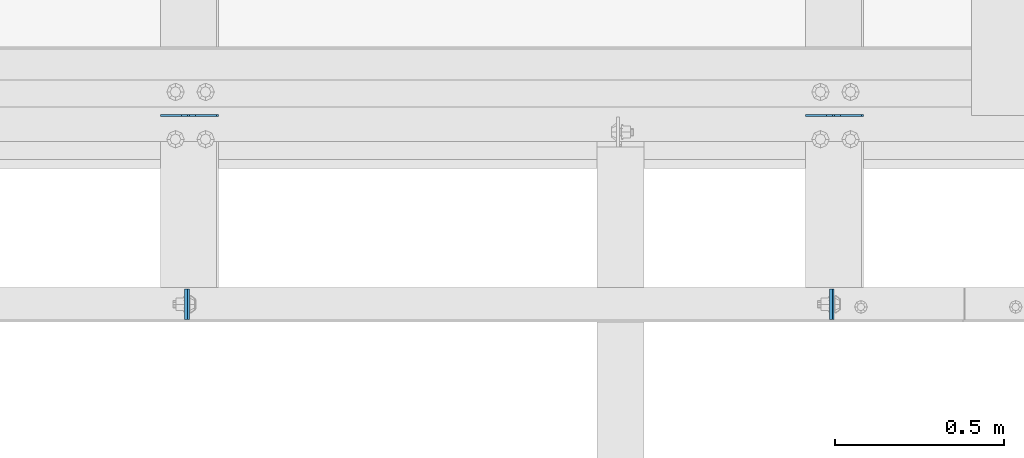
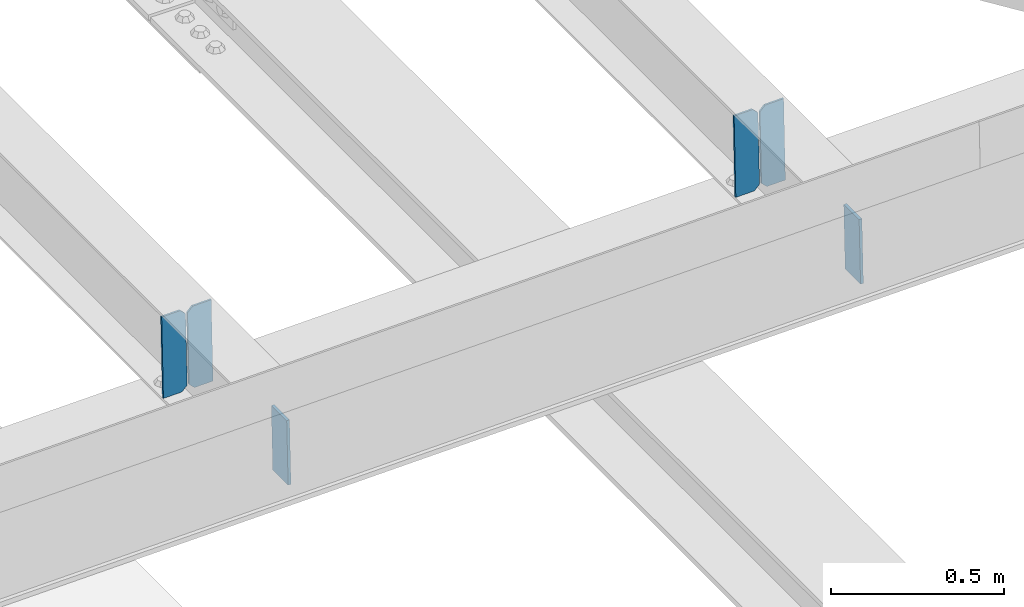
# One storey, part 3187 of 3843: 6 plates, 3 elements without a shape of their own.
"""IFC2X3 building model written with IfcOpenShell, lengths in millimetres."""

from ifc_helpers import new_model, si_unit, frame, origin_with_axes, place, context, subcontext, project, spatial, faceted_brep, material, type_object, element, aggregate, save


model = new_model("IFC2X3")

# Units and contexts
model_context = context("Model", 3, precision=1e-05, world=origin_with_axes())
body_context = subcontext(model_context, "Body", "Model", "MODEL_VIEW")
ifc_project = project(units=[si_unit("LENGTHUNIT", "METRE", prefix="MILLI"), si_unit("AREAUNIT", "SQUARE_METRE"), si_unit("VOLUMEUNIT", "CUBIC_METRE"), si_unit("MASSUNIT", "GRAM", prefix="KILO"), si_unit("TIMEUNIT", "SECOND"), si_unit("PLANEANGLEUNIT", "RADIAN"), si_unit("SOLIDANGLEUNIT", "STERADIAN"), si_unit("THERMODYNAMICTEMPERATUREUNIT", "DEGREE_CELSIUS"), si_unit("LUMINOUSINTENSITYUNIT", "LUMEN")], contexts=[model_context])

# Site, building, storey
site_placement = place(None, origin_with_axes())
site = spatial("IfcSite", under=ifc_project, at=site_placement, CompositionType="ELEMENT")
building_placement = place(site_placement, origin_with_axes())
building = spatial("IfcBuilding", under=site, at=building_placement, Name="Undefined", CompositionType="ELEMENT")
storey_placement = place(building_placement, origin_with_axes())
storey = spatial("IfcBuildingStorey", under=building, at=storey_placement, Name="Undefined", CompositionType="ELEMENT", Elevation=0.0)

# Assembly, plates
assembly_1_placement = place(storey_placement, origin_with_axes())
assembly_1 = element("IfcElementAssembly", 1, at=assembly_1_placement, inside=storey, Name="BEAM", AssemblyPlace="NOTDEFINED", PredefinedType="RIGID_FRAME")
ifc_material = material(Name="STEEL/A572-50")
plate_type_1 = type_object("IfcPlateType", PredefinedType="NOTDEFINED")
plate_1_placement = place(assembly_1_placement, frame((68337.6870661748, 25014.2376747884, 46363.5539819996), z_axis=(3.66789997933665e-05, 0.999999999327024, 7.76010238041635e-07), x_axis=(0.0211520550054438, 0.0, -0.999776270257025)))
plate_1 = element("IfcPlate", 2, at=plate_1_placement, type_object=plate_type_1, material=ifc_material, Name="PLATE", context=body_context, shape_type="Brep", body=[
    faceted_brep([(0.0, -4.76249999999709, 0.0), (0.0, -4.76249999999709, 88.9000015258789), (0.0, 4.76249999999709, 88.9000015258789), (0.0, 4.76249999999709, 0.0), (228.600006102781, -4.7625000004191, 88.9000015257589), (228.600006102781, 4.76249999954598, 88.9000015257443), (228.600006103079, -4.7625000004482, 7.27595761418343e-12), (228.600006103079, 4.76249999954598, -7.27595761418343e-12)], [[[0, 1, 2, 3]], [[1, 4, 5, 2]], [[4, 6, 7, 5]], [[6, 0, 3, 7]], [[5, 7, 3, 2]], [[6, 4, 1, 0]]]),
])
plate_2_placement = place(assembly_1_placement, frame((66432.6871638018, 25014.2376643107, 46323.2447316255), z_axis=(3.44799897284247e-05, 0.999999999405299, 7.29486360796727e-07), x_axis=(0.0211520550054438, 0.0, -0.999776270257025)))
plate_2 = element("IfcPlate", 3, at=plate_2_placement, type_object=plate_type_1, material=ifc_material, Name="PLATE", context=body_context, shape_type="Brep", body=[
    faceted_brep([(0.0, -4.76249999999709, 0.0), (0.0, -4.76249999999709, 88.9000015258789), (0.0, 4.76249999999709, 88.9000015258789), (0.0, 4.76249999999709, 0.0), (228.600006102781, -4.7625000004191, 88.9000015257589), (228.600006102781, 4.76249999954598, 88.9000015257443), (228.600006103079, -4.7625000004482, 7.27595761418343e-12), (228.600006103079, 4.76249999954598, -7.27595761418343e-12)], [[[0, 1, 2, 3]], [[1, 4, 5, 2]], [[4, 6, 7, 5]], [[6, 0, 3, 7]], [[5, 7, 3, 2]], [[6, 4, 1, 0]]]),
])
aggregate(assembly_1, [plate_1, plate_2])

assembly_2_placement = place(storey_placement, origin_with_axes())
assembly_2 = element("IfcElementAssembly", 4, at=assembly_2_placement, inside=storey, Name="BEAM", AssemblyPlace="NOTDEFINED", PredefinedType="RIGID_FRAME")
plate_type_2 = type_object("IfcPlateType", PredefinedType="NOTDEFINED")
plate_3_placement = place(assembly_2_placement, frame((68433.696478264, 25616.6676028813, 46104.5565711542), z_axis=(-0.0211520978230692, -0.00173405299920705, 0.99977476554366), x_axis=(-0.99977626935114, 3.66869999923657e-05, -0.0211520660073878)))
plate_3 = element("IfcPlate", 5, at=plate_3_placement, type_object=plate_type_2, material=ifc_material, Name="STIFFENER", context=body_context, shape_type="Brep", body=[
    faceted_brep([(0.0, -3.17499999999927, 0.0), (6.83940015733242e-10, -3.17499999996653, 288.924999998613), (6.54836185276508e-10, 3.17500000001746, 288.924999998591), (0.0, 3.17499999999927, 0.0), (61.9125003828667, -3.17499999997744, 288.924999998599), (61.9125003828522, 3.17500000002838, 288.924999998584), (79.3750000013097, -3.17499999997744, 271.462500380039), (79.375000001266, 3.17500000002838, 271.462500380017), (79.375000000713, -3.17499999999927, 17.4624996185448), (79.3750000006694, 3.17500000000291, 17.462499618523), (61.9125003821828, -3.17499999999563, -1.45519152283669e-11), (61.9125003821682, 3.17500000000655, -2.91038304567337e-11)], [[[0, 1, 2, 3]], [[1, 4, 5, 2]], [[4, 6, 7, 5]], [[6, 8, 9, 7]], [[8, 10, 11, 9]], [[10, 0, 3, 11]], [[5, 7, 9, 11, 3, 2]], [[10, 8, 6, 4, 1, 0]]]),
])
plate_4_placement = place(assembly_2_placement, frame((68347.9906575737, 25616.67074788, 46102.7433102814), z_axis=(-0.0211520978230692, -0.00173405299920705, 0.99977476554366), x_axis=(-0.99977626935114, 3.66869999923657e-05, -0.0211520660073878)))
plate_4 = element("IfcPlate", 6, at=plate_4_placement, type_object=plate_type_2, material=ifc_material, Name="STIFFENER", context=body_context, shape_type="Brep", body=[
    faceted_brep([(5.82076609134674e-11, -3.17499999999927, 17.4624996185667), (6.25732354819775e-10, -3.17499999997744, 271.462500380054), (5.82076609134674e-10, 3.17500000002474, 271.462500380039), (0.0, 3.17500000000655, 17.4624996185521), (17.462499619156, -3.17499999997744, 288.924999998606), (17.4624996191269, 3.17500000002474, 288.924999998591), (79.3750000013242, -3.17500000025029, 288.924999998591), (79.3750000013097, 3.1749999997337, 288.92499999857), (79.3750000006548, -3.17500000026484, -2.18278728425503e-11), (79.3750000006403, 3.17499999969732, -2.91038304567337e-11), (17.4624996184866, -3.17500000000291, 7.27595761418343e-12), (17.462499618443, 3.17500000000291, -7.27595761418343e-12)], [[[0, 1, 2, 3]], [[1, 4, 5, 2]], [[4, 6, 7, 5]], [[6, 8, 9, 7]], [[8, 10, 11, 9]], [[10, 0, 3, 11]], [[5, 7, 9, 11, 3, 2]], [[10, 8, 6, 4, 1, 0]]]),
])
aggregate(assembly_2, [plate_3, plate_4])

assembly_3_placement = place(storey_placement, origin_with_axes())
assembly_3 = element("IfcElementAssembly", 7, at=assembly_3_placement, inside=storey, Name="BEAM", AssemblyPlace="NOTDEFINED", PredefinedType="RIGID_FRAME")
plate_5_placement = place(assembly_3_placement, frame((66528.6964782672, 25616.6215250938, 46064.1892617647), z_axis=(-0.0211520981232898, -0.00163009300072372, 0.999774940444994), x_axis=(-0.999776269344788, 3.44879999965181e-05, -0.0211520700073351)))
plate_5 = element("IfcPlate", 8, at=plate_5_placement, type_object=plate_type_2, material=ifc_material, Name="STIFFENER", context=body_context, shape_type="Brep", body=[
    faceted_brep([(0.0, -3.17499999999927, 0.0), (6.83940015733242e-10, -3.17499999996653, 288.924999998613), (6.54836185276508e-10, 3.17500000001746, 288.924999998591), (0.0, 3.17499999999927, 0.0), (61.9125003828667, -3.17499999997744, 288.924999998599), (61.9125003828522, 3.17500000002838, 288.924999998584), (79.3750000013097, -3.17499999997744, 271.462500380039), (79.375000001266, 3.17500000002838, 271.462500380017), (79.375000000713, -3.17499999999927, 17.4624996185448), (79.3750000006694, 3.17500000000291, 17.462499618523), (61.9125003821828, -3.17499999999563, -1.45519152283669e-11), (61.9125003821682, 3.17500000000655, -2.91038304567337e-11)], [[[0, 1, 2, 3]], [[1, 4, 5, 2]], [[4, 6, 7, 5]], [[6, 8, 9, 7]], [[8, 10, 11, 9]], [[10, 0, 3, 11]], [[5, 7, 9, 11, 3, 2]], [[10, 8, 6, 4, 1, 0]]]),
])
plate_6_placement = place(assembly_3_placement, frame((66442.990657577, 25616.6244815435, 46062.3760005729), z_axis=(-0.0211520981232898, -0.00163009300072372, 0.999774940444994), x_axis=(-0.999776269344788, 3.44879999965181e-05, -0.0211520700073351)))
plate_6 = element("IfcPlate", 9, at=plate_6_placement, type_object=plate_type_2, material=ifc_material, Name="STIFFENER", context=body_context, shape_type="Brep", body=[
    faceted_brep([(5.82076609134674e-11, -3.17499999999927, 17.4624996185667), (6.25732354819775e-10, -3.17499999997744, 271.462500380054), (5.82076609134674e-10, 3.17500000002474, 271.462500380039), (0.0, 3.17500000000655, 17.4624996185521), (17.462499619156, -3.17499999997744, 288.924999998606), (17.4624996191269, 3.17500000002474, 288.924999998591), (79.3750000013242, -3.17500000025029, 288.924999998591), (79.3750000013097, 3.1749999997337, 288.92499999857), (79.3750000006548, -3.17500000026484, -2.18278728425503e-11), (79.3750000006403, 3.17499999969732, -2.91038304567337e-11), (17.4624996184866, -3.17500000000291, 7.27595761418343e-12), (17.462499618443, 3.17500000000291, -7.27595761418343e-12)], [[[0, 1, 2, 3]], [[1, 4, 5, 2]], [[4, 6, 7, 5]], [[6, 8, 9, 7]], [[8, 10, 11, 9]], [[10, 0, 3, 11]], [[5, 7, 9, 11, 3, 2]], [[10, 8, 6, 4, 1, 0]]]),
])
aggregate(assembly_3, [plate_5, plate_6])

save(model, "model.ifc")
